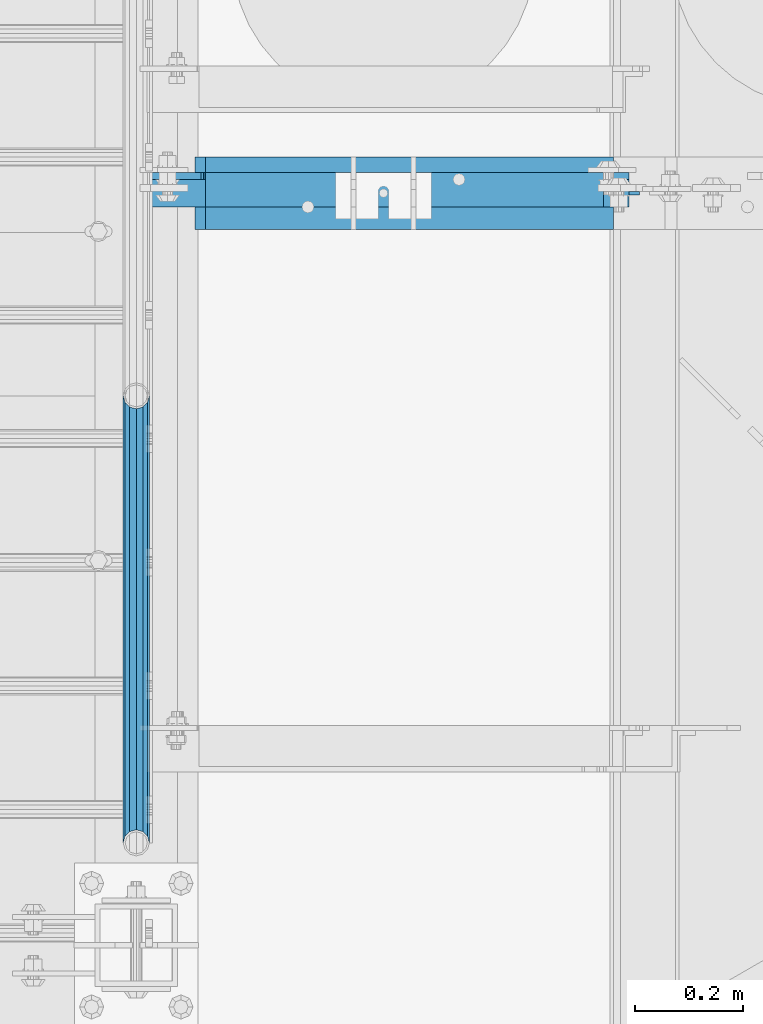
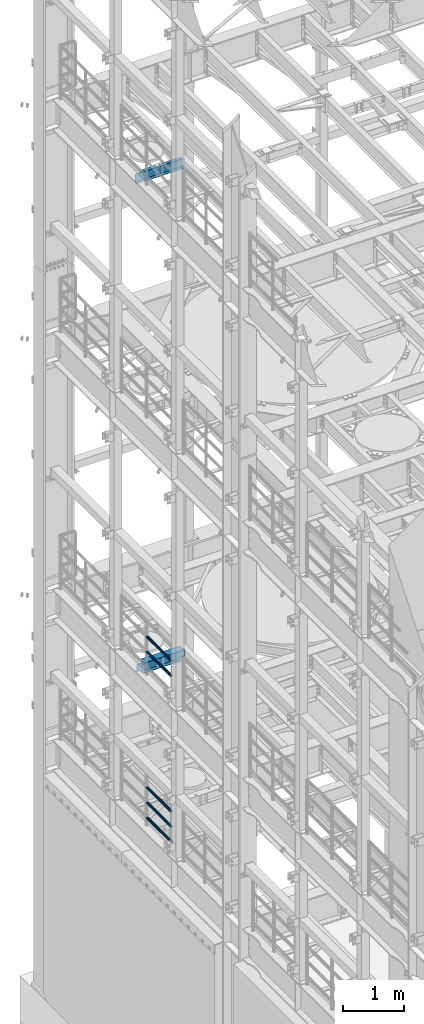
# One storey, part 1304 of 1876: 7 beams, 4 elements without a shape of their own.
"""IFC2X3 building model written with IfcOpenShell, lengths in millimetres."""

from ifc_helpers import new_model, si_unit, frame, origin_with_axes, place, context, subcontext, project, spatial, faceted_brep, material, type_object, element, aggregate, save


model = new_model("IFC2X3")

# Units and contexts
model_context = context("Model", 3, precision=1e-05, world=origin_with_axes())
body_context = subcontext(model_context, "Body", "Model", "MODEL_VIEW")
ifc_project = project(units=[si_unit("LENGTHUNIT", "METRE", prefix="MILLI"), si_unit("AREAUNIT", "SQUARE_METRE"), si_unit("VOLUMEUNIT", "CUBIC_METRE"), si_unit("MASSUNIT", "GRAM", prefix="KILO"), si_unit("TIMEUNIT", "SECOND"), si_unit("PLANEANGLEUNIT", "RADIAN"), si_unit("SOLIDANGLEUNIT", "STERADIAN"), si_unit("THERMODYNAMICTEMPERATUREUNIT", "DEGREE_CELSIUS"), si_unit("LUMINOUSINTENSITYUNIT", "LUMEN")], contexts=[model_context])

# Site, building, storey
site_placement = place(None, origin_with_axes())
site = spatial("IfcSite", under=ifc_project, at=site_placement, CompositionType="ELEMENT")
building_placement = place(site_placement, origin_with_axes())
building = spatial("IfcBuilding", under=site, at=building_placement, Name="Undefined", CompositionType="ELEMENT")
storey_placement = place(building_placement, origin_with_axes())
storey = spatial("IfcBuildingStorey", under=building, at=storey_placement, Name="Undefined", CompositionType="ELEMENT", Elevation=0.0)

# Assembly, beams
assembly_1_placement = place(storey_placement, origin_with_axes())
assembly_1 = element("IfcElementAssembly", 1, at=assembly_1_placement, inside=storey, Name="RAIL", AssemblyPlace="NOTDEFINED", PredefinedType="RIGID_FRAME")
ifc_material_1 = material()
beam_type_1 = type_object("IfcBeamType", Name="PIPE1-1/2SCH40", PredefinedType="NOTDEFINED")
beam_1_placement = place(assembly_1_placement, frame((-1.81898940354586e-12, 9841.23, 8620.125), z_axis=(0.0, 0.0, -1.0), x_axis=(0.0, 1.0, 0.0)))
beam_1 = element("IfcBeam", 2, at=beam_1_placement, type_object=beam_type_1, material=ifc_material_1, Name="RAIL", ObjectType="PIPE1-1/2SCH40", context=body_context, shape_type="Brep", body=[
    faceted_brep([(0.0, 24.1299999999992, 0.0), (12.0650000000064, 20.8971929933177, -12.0649999999987), (12.0650000000064, 20.8971929933177, 12.0649999999987), (12.0650000000064, -20.8971929933177, 12.0649999999987), (12.0650000000064, -20.8971929933177, -12.0649999999987), (0.0, -24.1299999999992, 0.0), (20.8971929933249, -12.0650000000005, 20.8971929933177), (20.8971929933249, -12.0650000000005, 15.8661214311796), (15.2545715621445, -17.7076214311801, 10.2235000000001), (12.5151929933249, -20.4470000000001, 0.0), (15.2545715621445, -17.7076214311801, -10.2235000000001), (20.8971929933249, -12.0650000000005, -15.8661214311796), (20.8971929933249, -12.0650000000005, -20.8971929933177), (24.1300000000063, 0.0, -20.4470000000001), (24.1300000000063, 0.0, -24.130000000001), (21.3906214311868, -10.2235000000001, -17.7076214311819), (21.3906214311868, 10.2235000000001, -17.7076214311819), (20.8971929933249, 12.0650000000005, -15.8661214311796), (20.8971929933249, 12.0650000000005, -20.8971929933177), (15.2545715621445, 17.7076214311801, -10.2235000000001), (12.5151929933249, 20.4470000000001, 0.0), (15.2545715621445, 17.7076214311801, 10.2235000000001), (20.8971929933249, 12.0650000000005, 15.8661214311796), (20.8971929933249, 12.0650000000005, 20.8971929933177), (21.3906214311868, 10.2235000000001, 17.7076214311819), (24.1300000000064, 0.0, 20.4470000000001), (24.1300000000064, 0.0, 24.130000000001), (21.3906214311868, -10.2235000000001, 17.7076214311819), (826.77, 24.1300000000001, 0.0), (814.705, 20.8971929933186, -12.0649999999987), (805.872807006681, 12.0649999999996, -20.8971929933177), (826.77, -24.1300000000001, 0.0), (814.705, -20.8971929933186, -12.0649999999987), (814.705, -20.8971929933186, 12.0649999999987), (805.872807006681, -12.0649999999996, 20.8971929933177), (805.872807006681, -12.0649999999996, -20.8971929933177), (802.640000000001, 0.0, -24.130000000001), (805.379378568819, 10.2235000000001, -17.7076214311819), (802.640000000001, 0.0, -20.4470000000001), (805.872807006683, 12.0649999999996, -15.8661214311796), (805.872807006683, -12.0649999999996, -15.8661214311796), (805.379378568819, -10.2235000000001, -17.7076214311819), (811.515428437862, -17.7076214311801, -10.2235000000001), (814.254807006682, -20.4470000000001, 0.0), (811.515428437862, -17.7076214311801, 10.2235000000001), (805.872807006683, -12.0649999999996, 15.8661214311796), (805.379378568819, -10.2235000000001, 17.7076214311819), (802.640000000001, 0.0, 20.4470000000001), (802.640000000001, 0.0, 24.130000000001), (805.872807006681, 12.0649999999996, 20.8971929933177), (814.705, 20.8971929933186, 12.0649999999987), (805.872807006683, 12.0649999999996, 15.8661214311796), (811.515428437862, 17.7076214311801, 10.2235000000001), (814.254807006682, 20.4470000000001, 0.0), (811.515428437862, 17.7076214311801, -10.2235000000001), (805.379378568819, 10.2235000000001, 17.7076214311819)], [[[0, 1, 2]], [[3, 4, 5]], [[6, 7, 8, 9, 10, 11, 12, 4, 3]], [[13, 14, 12, 11, 15]], [[16, 17, 18, 14, 13]], [[2, 1, 18, 17, 19, 20, 21, 22, 23]], [[23, 22, 24, 25, 26]], [[26, 25, 27, 7, 6]], [[1, 0, 28, 29]], [[18, 1, 29, 30]], [[31, 32, 33]], [[6, 3, 33, 34]], [[3, 5, 31, 33]], [[5, 4, 32, 31]], [[4, 12, 35, 32]], [[12, 14, 36, 35]], [[14, 18, 30, 36]], [[37, 38, 36, 30, 39]], [[40, 35, 36, 38, 41]], [[33, 32, 35, 40, 42, 43, 44, 45, 34]], [[34, 45, 46, 47, 48]], [[26, 6, 34, 48]], [[2, 23, 49, 50]], [[23, 26, 48, 49]], [[0, 2, 50, 28]], [[28, 50, 29]], [[49, 51, 52, 53, 54, 39, 30, 29, 50]], [[48, 47, 55, 51, 49]], [[25, 24, 55, 47]], [[55, 24, 22, 21, 52, 51]], [[21, 20, 53, 52]], [[20, 19, 54, 53]], [[19, 17, 16, 37, 39, 54]], [[16, 13, 38, 37]], [[13, 15, 41, 38]], [[41, 15, 11, 10, 42, 40]], [[10, 9, 43, 42]], [[9, 8, 44, 43]], [[8, 7, 27, 46, 45, 44]], [[27, 25, 47, 46]]]),
])
beam_2_placement = place(assembly_1_placement, frame((-1.81898940354586e-12, 9841.23, 8924.925), z_axis=(0.0, 0.0, -1.0), x_axis=(0.0, 1.0, 0.0)))
beam_2 = element("IfcBeam", 3, at=beam_2_placement, type_object=beam_type_1, material=ifc_material_1, Name="RAIL", ObjectType="PIPE1-1/2SCH40", context=body_context, shape_type="Brep", body=[
    faceted_brep([(0.0, 24.1299999999992, 0.0), (12.0650000000064, 20.8971929933177, -12.0649999999987), (12.0650000000064, 20.8971929933177, 12.0649999999987), (12.0650000000064, -20.8971929933177, 12.0649999999987), (12.0650000000064, -20.8971929933177, -12.0649999999987), (0.0, -24.1299999999992, 0.0), (20.8971929933249, -12.0650000000005, 20.8971929933177), (20.8971929933249, -12.0650000000005, 15.8661214311796), (15.2545715621445, -17.7076214311801, 10.2235000000001), (12.5151929933249, -20.4470000000001, 0.0), (15.2545715621445, -17.7076214311801, -10.2235000000001), (20.8971929933249, -12.0650000000005, -15.8661214311796), (20.8971929933249, -12.0650000000005, -20.8971929933177), (24.1300000000063, 0.0, -20.4470000000001), (24.1300000000063, 0.0, -24.130000000001), (21.3906214311868, -10.2235000000001, -17.7076214311819), (21.3906214311868, 10.2235000000001, -17.7076214311819), (20.8971929933249, 12.0650000000005, -15.8661214311796), (20.8971929933249, 12.0650000000005, -20.8971929933177), (15.2545715621445, 17.7076214311801, -10.2235000000001), (12.5151929933249, 20.4470000000001, 0.0), (15.2545715621445, 17.7076214311801, 10.2235000000001), (20.8971929933249, 12.0650000000005, 15.8661214311796), (20.8971929933249, 12.0650000000005, 20.8971929933177), (21.3906214311868, 10.2235000000001, 17.7076214311819), (24.1300000000064, 0.0, 20.4470000000001), (24.1300000000064, 0.0, 24.130000000001), (21.3906214311868, -10.2235000000001, 17.7076214311819), (826.77, 24.1300000000001, 0.0), (814.705, 20.8971929933186, -12.0649999999987), (805.872807006681, 12.0649999999996, -20.8971929933177), (826.77, -24.1300000000001, 0.0), (814.705, -20.8971929933186, -12.0649999999987), (814.705, -20.8971929933186, 12.0649999999987), (805.872807006681, -12.0649999999996, 20.8971929933177), (805.872807006681, -12.0649999999996, -20.8971929933177), (802.640000000001, 0.0, -24.130000000001), (805.379378568819, 10.2235000000001, -17.7076214311819), (802.640000000001, 0.0, -20.4470000000001), (805.872807006683, 12.0649999999996, -15.8661214311796), (805.872807006683, -12.0649999999996, -15.8661214311796), (805.379378568819, -10.2235000000001, -17.7076214311819), (811.515428437862, -17.7076214311801, -10.2235000000001), (814.254807006682, -20.4470000000001, 0.0), (811.515428437862, -17.7076214311801, 10.2235000000001), (805.872807006683, -12.0649999999996, 15.8661214311796), (805.379378568819, -10.2235000000001, 17.7076214311819), (802.640000000001, 0.0, 20.4470000000001), (802.640000000001, 0.0, 24.130000000001), (805.872807006681, 12.0649999999996, 20.8971929933177), (814.705, 20.8971929933186, 12.0649999999987), (805.872807006683, 12.0649999999996, 15.8661214311796), (811.515428437862, 17.7076214311801, 10.2235000000001), (814.254807006682, 20.4470000000001, 0.0), (811.515428437862, 17.7076214311801, -10.2235000000001), (805.379378568819, 10.2235000000001, 17.7076214311819)], [[[0, 1, 2]], [[3, 4, 5]], [[6, 7, 8, 9, 10, 11, 12, 4, 3]], [[13, 14, 12, 11, 15]], [[16, 17, 18, 14, 13]], [[2, 1, 18, 17, 19, 20, 21, 22, 23]], [[23, 22, 24, 25, 26]], [[26, 25, 27, 7, 6]], [[1, 0, 28, 29]], [[18, 1, 29, 30]], [[31, 32, 33]], [[6, 3, 33, 34]], [[3, 5, 31, 33]], [[5, 4, 32, 31]], [[4, 12, 35, 32]], [[12, 14, 36, 35]], [[14, 18, 30, 36]], [[37, 38, 36, 30, 39]], [[40, 35, 36, 38, 41]], [[33, 32, 35, 40, 42, 43, 44, 45, 34]], [[34, 45, 46, 47, 48]], [[26, 6, 34, 48]], [[2, 23, 49, 50]], [[23, 26, 48, 49]], [[0, 2, 50, 28]], [[28, 50, 29]], [[49, 51, 52, 53, 54, 39, 30, 29, 50]], [[48, 47, 55, 51, 49]], [[25, 24, 55, 47]], [[55, 24, 22, 21, 52, 51]], [[21, 20, 53, 52]], [[20, 19, 54, 53]], [[19, 17, 16, 37, 39, 54]], [[16, 13, 38, 37]], [[13, 15, 41, 38]], [[41, 15, 11, 10, 42, 40]], [[10, 9, 43, 42]], [[9, 8, 44, 43]], [[8, 7, 27, 46, 45, 44]], [[27, 25, 47, 46]]]),
])
aggregate(assembly_1, [beam_1, beam_2])

assembly_2_placement = place(storey_placement, origin_with_axes())
assembly_2 = element("IfcElementAssembly", 4, at=assembly_2_placement, inside=storey, Name="RAIL", AssemblyPlace="NOTDEFINED", PredefinedType="RIGID_FRAME")
beam_3_placement = place(assembly_2_placement, frame((-1.81898940354586e-12, 10668.0, 5292.725), z_axis=(0.0, 0.0, 1.0), x_axis=(0.0, -1.0, 0.0)))
beam_3 = element("IfcBeam", 5, at=beam_3_placement, type_object=beam_type_1, material=ifc_material_1, Name="RAIL", ObjectType="PIPE1-1/2SCH40", context=body_context, shape_type="Brep", body=[
    faceted_brep([(805.872807006681, -12.0649999999996, 20.8971929933177), (805.872807006683, -12.0649999999996, 15.8661214311796), (805.379378568819, -10.2235000000001, 17.7076214311819), (802.640000000001, 0.0, 20.4470000000001), (802.640000000001, 0.0, 24.130000000001), (805.379378568819, 10.2235000000001, 17.7076214311819), (805.872807006683, 12.0649999999996, 15.8661214311796), (805.872807006681, 12.0649999999996, 20.8971929933177), (826.77, 24.1300000000001, 0.0), (814.705, 20.8971929933186, 12.0649999999987), (814.705, 20.8971929933186, -12.0649999999987), (811.515428437862, 17.7076214311801, 10.2235000000001), (814.254807006682, 20.4470000000001, 0.0), (811.515428437862, 17.7076214311801, -10.2235000000001), (805.872807006683, 12.0649999999996, -15.8661214311796), (805.872807006681, 12.0649999999996, -20.8971929933177), (805.379378568819, 10.2235000000001, -17.7076214311819), (802.640000000001, 0.0, -20.4470000000001), (802.640000000001, 0.0, -24.130000000001), (805.872807006683, -12.0649999999996, -15.8661214311796), (805.872807006681, -12.0649999999996, -20.8971929933177), (805.379378568819, -10.2235000000001, -17.7076214311819), (826.77, -24.1300000000001, 0.0), (814.705, -20.8971929933186, -12.0649999999987), (814.705, -20.8971929933186, 12.0649999999987), (811.515428437862, -17.7076214311801, -10.2235000000001), (814.254807006682, -20.4470000000001, 0.0), (811.515428437862, -17.7076214311801, 10.2235000000001), (12.0650000000064, -20.8971929933177, -12.0649999999987), (20.8971929933249, -12.0650000000005, -20.8971929933177), (0.0, 24.1299999999992, 0.0), (12.0650000000064, 20.8971929933177, -12.0649999999987), (12.0650000000064, 20.8971929933177, 12.0649999999987), (20.8971929933249, 12.0650000000005, 20.8971929933177), (24.1300000000064, 0.0, 24.130000000001), (20.8971929933249, 12.0650000000005, -20.8971929933177), (24.1300000000063, 0.0, -24.130000000001), (24.1300000000063, 0.0, -20.4470000000001), (20.8971929933249, -12.0650000000005, -15.8661214311796), (21.3906214311868, -10.2235000000001, -17.7076214311819), (21.3906214311868, 10.2235000000001, -17.7076214311819), (20.8971929933249, 12.0650000000005, -15.8661214311796), (15.2545715621445, 17.7076214311801, -10.2235000000001), (12.5151929933249, 20.4470000000001, 0.0), (15.2545715621445, 17.7076214311801, 10.2235000000001), (20.8971929933249, 12.0650000000005, 15.8661214311796), (21.3906214311868, 10.2235000000001, 17.7076214311819), (24.1300000000064, 0.0, 20.4470000000001), (21.3906214311868, -10.2235000000001, 17.7076214311819), (20.8971929933249, -12.0650000000005, 15.8661214311796), (20.8971929933249, -12.0650000000005, 20.8971929933177), (12.0650000000064, -20.8971929933177, 12.0649999999987), (0.0, -24.1299999999992, 0.0), (15.2545715621445, -17.7076214311801, 10.2235000000001), (12.5151929933249, -20.4470000000001, 0.0), (15.2545715621445, -17.7076214311801, -10.2235000000001)], [[[0, 1, 2, 3, 4]], [[4, 3, 5, 6, 7]], [[8, 9, 10]], [[7, 6, 11, 12, 13, 14, 15, 10, 9]], [[16, 17, 18, 15, 14]], [[19, 20, 18, 17, 21]], [[22, 23, 24]], [[24, 23, 20, 19, 25, 26, 27, 1, 0]], [[28, 29, 20, 23]], [[30, 31, 32]], [[33, 34, 4, 7]], [[32, 33, 7, 9]], [[30, 32, 9, 8]], [[31, 30, 8, 10]], [[35, 31, 10, 15]], [[36, 35, 15, 18]], [[29, 36, 18, 20]], [[37, 36, 29, 38, 39]], [[40, 41, 35, 36, 37]], [[32, 31, 35, 41, 42, 43, 44, 45, 33]], [[33, 45, 46, 47, 34]], [[34, 47, 48, 49, 50]], [[34, 50, 0, 4]], [[50, 51, 24, 0]], [[51, 52, 22, 24]], [[52, 28, 23, 22]], [[51, 28, 52]], [[50, 49, 53, 54, 55, 38, 29, 28, 51]], [[55, 54, 26, 25]], [[21, 39, 38, 55, 25, 19]], [[37, 39, 21, 17]], [[40, 37, 17, 16]], [[42, 41, 40, 16, 14, 13]], [[43, 42, 13, 12]], [[44, 43, 12, 11]], [[5, 46, 45, 44, 11, 6]], [[47, 46, 5, 3]], [[48, 47, 3, 2]], [[53, 49, 48, 2, 1, 27]], [[54, 53, 27, 26]]]),
])
beam_4_placement = place(assembly_2_placement, frame((-1.81898940354586e-12, 9841.23, 5597.525), z_axis=(0.0, 0.0, -1.0), x_axis=(0.0, 1.0, 0.0)))
beam_4 = element("IfcBeam", 6, at=beam_4_placement, type_object=beam_type_1, material=ifc_material_1, Name="RAIL", ObjectType="PIPE1-1/2SCH40", context=body_context, shape_type="Brep", body=[
    faceted_brep([(0.0, 24.1299999999992, 0.0), (12.0650000000064, 20.8971929933177, -12.0649999999987), (12.0650000000064, 20.8971929933177, 12.0649999999987), (12.0650000000064, -20.8971929933177, 12.0649999999987), (12.0650000000064, -20.8971929933177, -12.0649999999987), (0.0, -24.1299999999992, 0.0), (20.8971929933249, -12.0650000000005, 20.8971929933177), (20.8971929933249, -12.0650000000005, 15.8661214311796), (15.2545715621445, -17.7076214311801, 10.2235000000001), (12.5151929933249, -20.4470000000001, 0.0), (15.2545715621445, -17.7076214311801, -10.2235000000001), (20.8971929933249, -12.0650000000005, -15.8661214311796), (20.8971929933249, -12.0650000000005, -20.8971929933177), (24.1300000000063, 0.0, -20.4470000000001), (24.1300000000063, 0.0, -24.130000000001), (21.3906214311868, -10.2235000000001, -17.7076214311819), (21.3906214311868, 10.2235000000001, -17.7076214311819), (20.8971929933249, 12.0650000000005, -15.8661214311796), (20.8971929933249, 12.0650000000005, -20.8971929933177), (15.2545715621445, 17.7076214311801, -10.2235000000001), (12.5151929933249, 20.4470000000001, 0.0), (15.2545715621445, 17.7076214311801, 10.2235000000001), (20.8971929933249, 12.0650000000005, 15.8661214311796), (20.8971929933249, 12.0650000000005, 20.8971929933177), (21.3906214311868, 10.2235000000001, 17.7076214311819), (24.1300000000064, 0.0, 20.4470000000001), (24.1300000000064, 0.0, 24.130000000001), (21.3906214311868, -10.2235000000001, 17.7076214311819), (826.77, 24.1300000000001, 0.0), (814.705, 20.8971929933186, -12.0649999999987), (805.872807006681, 12.0649999999996, -20.8971929933177), (826.77, -24.1300000000001, 0.0), (814.705, -20.8971929933186, -12.0649999999987), (814.705, -20.8971929933186, 12.0649999999987), (805.872807006681, -12.0649999999996, 20.8971929933177), (805.872807006681, -12.0649999999996, -20.8971929933177), (802.640000000001, 0.0, -24.130000000001), (805.379378568819, 10.2235000000001, -17.7076214311819), (802.640000000001, 0.0, -20.4470000000001), (805.872807006683, 12.0649999999996, -15.8661214311796), (805.872807006683, -12.0649999999996, -15.8661214311796), (805.379378568819, -10.2235000000001, -17.7076214311819), (811.515428437862, -17.7076214311801, -10.2235000000001), (814.254807006682, -20.4470000000001, 0.0), (811.515428437862, -17.7076214311801, 10.2235000000001), (805.872807006683, -12.0649999999996, 15.8661214311796), (805.379378568819, -10.2235000000001, 17.7076214311819), (802.640000000001, 0.0, 20.4470000000001), (802.640000000001, 0.0, 24.130000000001), (805.872807006681, 12.0649999999996, 20.8971929933177), (814.705, 20.8971929933186, 12.0649999999987), (805.872807006683, 12.0649999999996, 15.8661214311796), (811.515428437862, 17.7076214311801, 10.2235000000001), (814.254807006682, 20.4470000000001, 0.0), (811.515428437862, 17.7076214311801, -10.2235000000001), (805.379378568819, 10.2235000000001, 17.7076214311819)], [[[0, 1, 2]], [[3, 4, 5]], [[6, 7, 8, 9, 10, 11, 12, 4, 3]], [[13, 14, 12, 11, 15]], [[16, 17, 18, 14, 13]], [[2, 1, 18, 17, 19, 20, 21, 22, 23]], [[23, 22, 24, 25, 26]], [[26, 25, 27, 7, 6]], [[1, 0, 28, 29]], [[18, 1, 29, 30]], [[31, 32, 33]], [[6, 3, 33, 34]], [[3, 5, 31, 33]], [[5, 4, 32, 31]], [[4, 12, 35, 32]], [[12, 14, 36, 35]], [[14, 18, 30, 36]], [[37, 38, 36, 30, 39]], [[40, 35, 36, 38, 41]], [[33, 32, 35, 40, 42, 43, 44, 45, 34]], [[34, 45, 46, 47, 48]], [[26, 6, 34, 48]], [[2, 23, 49, 50]], [[23, 26, 48, 49]], [[0, 2, 50, 28]], [[28, 50, 29]], [[49, 51, 52, 53, 54, 39, 30, 29, 50]], [[48, 47, 55, 51, 49]], [[25, 24, 55, 47]], [[55, 24, 22, 21, 52, 51]], [[21, 20, 53, 52]], [[20, 19, 54, 53]], [[19, 17, 16, 37, 39, 54]], [[16, 13, 38, 37]], [[13, 15, 41, 38]], [[41, 15, 11, 10, 42, 40]], [[10, 9, 43, 42]], [[9, 8, 44, 43]], [[8, 7, 27, 46, 45, 44]], [[27, 25, 47, 46]]]),
])
beam_5_placement = place(assembly_2_placement, frame((-1.81898940354586e-12, 9841.23, 5902.325), z_axis=(0.0, 0.0, -1.0), x_axis=(0.0, 1.0, 0.0)))
beam_5 = element("IfcBeam", 7, at=beam_5_placement, type_object=beam_type_1, material=ifc_material_1, Name="RAIL", ObjectType="PIPE1-1/2SCH40", context=body_context, shape_type="Brep", body=[
    faceted_brep([(0.0, 24.1299999999992, 0.0), (12.0650000000064, 20.8971929933177, -12.0649999999987), (12.0650000000064, 20.8971929933177, 12.0649999999987), (12.0650000000064, -20.8971929933177, 12.0649999999987), (12.0650000000064, -20.8971929933177, -12.0649999999987), (0.0, -24.1299999999992, 0.0), (20.8971929933249, -12.0650000000005, 20.8971929933177), (20.8971929933249, -12.0650000000005, 15.8661214311796), (15.2545715621445, -17.7076214311801, 10.2235000000001), (12.5151929933249, -20.4470000000001, 0.0), (15.2545715621445, -17.7076214311801, -10.2235000000001), (20.8971929933249, -12.0650000000005, -15.8661214311796), (20.8971929933249, -12.0650000000005, -20.8971929933177), (24.1300000000063, 0.0, -20.4470000000001), (24.1300000000063, 0.0, -24.130000000001), (21.3906214311868, -10.2235000000001, -17.7076214311819), (21.3906214311868, 10.2235000000001, -17.7076214311819), (20.8971929933249, 12.0650000000005, -15.8661214311796), (20.8971929933249, 12.0650000000005, -20.8971929933177), (15.2545715621445, 17.7076214311801, -10.2235000000001), (12.5151929933249, 20.4470000000001, 0.0), (15.2545715621445, 17.7076214311801, 10.2235000000001), (20.8971929933249, 12.0650000000005, 15.8661214311796), (20.8971929933249, 12.0650000000005, 20.8971929933177), (21.3906214311868, 10.2235000000001, 17.7076214311819), (24.1300000000064, 0.0, 20.4470000000001), (24.1300000000064, 0.0, 24.130000000001), (21.3906214311868, -10.2235000000001, 17.7076214311819), (826.77, 24.1300000000001, 0.0), (814.705, 20.8971929933186, -12.0649999999987), (805.872807006681, 12.0649999999996, -20.8971929933177), (826.77, -24.1300000000001, 0.0), (814.705, -20.8971929933186, -12.0649999999987), (814.705, -20.8971929933186, 12.0649999999987), (805.872807006681, -12.0649999999996, 20.8971929933177), (805.872807006681, -12.0649999999996, -20.8971929933177), (802.640000000001, 0.0, -24.130000000001), (805.379378568819, 10.2235000000001, -17.7076214311819), (802.640000000001, 0.0, -20.4470000000001), (805.872807006683, 12.0649999999996, -15.8661214311796), (805.872807006683, -12.0649999999996, -15.8661214311796), (805.379378568819, -10.2235000000001, -17.7076214311819), (811.515428437862, -17.7076214311801, -10.2235000000001), (814.254807006682, -20.4470000000001, 0.0), (811.515428437862, -17.7076214311801, 10.2235000000001), (805.872807006683, -12.0649999999996, 15.8661214311796), (805.379378568819, -10.2235000000001, 17.7076214311819), (802.640000000001, 0.0, 20.4470000000001), (802.640000000001, 0.0, 24.130000000001), (805.872807006681, 12.0649999999996, 20.8971929933177), (814.705, 20.8971929933186, 12.0649999999987), (805.872807006683, 12.0649999999996, 15.8661214311796), (811.515428437862, 17.7076214311801, 10.2235000000001), (814.254807006682, 20.4470000000001, 0.0), (811.515428437862, 17.7076214311801, -10.2235000000001), (805.379378568819, 10.2235000000001, 17.7076214311819)], [[[0, 1, 2]], [[3, 4, 5]], [[6, 7, 8, 9, 10, 11, 12, 4, 3]], [[13, 14, 12, 11, 15]], [[16, 17, 18, 14, 13]], [[2, 1, 18, 17, 19, 20, 21, 22, 23]], [[23, 22, 24, 25, 26]], [[26, 25, 27, 7, 6]], [[1, 0, 28, 29]], [[18, 1, 29, 30]], [[31, 32, 33]], [[6, 3, 33, 34]], [[3, 5, 31, 33]], [[5, 4, 32, 31]], [[4, 12, 35, 32]], [[12, 14, 36, 35]], [[14, 18, 30, 36]], [[37, 38, 36, 30, 39]], [[40, 35, 36, 38, 41]], [[33, 32, 35, 40, 42, 43, 44, 45, 34]], [[34, 45, 46, 47, 48]], [[26, 6, 34, 48]], [[2, 23, 49, 50]], [[23, 26, 48, 49]], [[0, 2, 50, 28]], [[28, 50, 29]], [[49, 51, 52, 53, 54, 39, 30, 29, 50]], [[48, 47, 55, 51, 49]], [[25, 24, 55, 47]], [[55, 24, 22, 21, 52, 51]], [[21, 20, 53, 52]], [[20, 19, 54, 53]], [[19, 17, 16, 37, 39, 54]], [[16, 13, 38, 37]], [[13, 15, 41, 38]], [[41, 15, 11, 10, 42, 40]], [[10, 9, 43, 42]], [[9, 8, 44, 43]], [[8, 7, 27, 46, 45, 44]], [[27, 25, 47, 46]]]),
])
aggregate(assembly_2, [beam_3, beam_4, beam_5])

# Assembly, beam
assembly_3_placement = place(storey_placement, origin_with_axes())
assembly_3 = element("IfcElementAssembly", 8, at=assembly_3_placement, inside=storey, Name="BEAM", AssemblyPlace="NOTDEFINED", PredefinedType="RIGID_FRAME")
ifc_material_2 = material(Name="STEEL/A992")
beam_type_2 = type_object("IfcBeamType", Name="W8X18", PredefinedType="NOTDEFINED")
beam_6_placement = place(assembly_3_placement, frame((0.0, 11042.65, 8050.2125), z_axis=(0.0, 0.0, 1.0), x_axis=(1.0, 0.0, 0.0)))
beam_6 = element("IfcBeam", 9, at=beam_6_placement, type_object=beam_type_2, material=ifc_material_2, Name="BEAM", ObjectType="W8X18", context=body_context, shape_type="Brep", body=[
    faceted_brep([(19.8437500000002, -3.17500000000018, -77.7874999999985), (19.8437500000002, 3.17500000000018, -77.7874999999985), (96.043750190735, 3.17499999999927, -77.7875000000004), (96.043750190735, -3.17499999999927, -77.7875000000004), (100.903829708781, 3.17499999999927, -78.7542299225879), (100.903829708781, -3.17499999999927, -78.7542299225879), (105.024006176934, 3.17499999999927, -81.5072438230654), (105.024006176934, -3.17499999999927, -81.5072438230654), (107.777020077412, 3.17499999999927, -85.6274202912191), (107.777020077412, -3.17499999999927, -85.6274202912191), (108.74375, -3.17499999999927, -90.4874998092655), (108.74375, 3.17499999999927, -90.4874998092655), (108.74375, 3.17499999999927, -95.25), (108.74375, 66.6749999999993, -95.25), (108.74375, 66.6750000000002, -103.1875), (108.74375, -66.6750000000002, -103.1875), (108.74375, -66.6749999999993, -95.25), (108.74375, -3.17499999999927, -95.25), (127.79375, 66.6749999999993, 103.1875), (127.79375, -66.6749999999993, 103.1875), (882.649999999999, -66.6749999999993, 103.1875), (882.649999999999, 66.6749999999993, 103.1875), (127.79375, -66.6749999999993, 95.25), (882.965773345275, -66.6749999999993, 95.25), (882.649999999999, -66.6749999999993, 96.837499809264), (882.649999999999, 66.6749999999993, 96.837499809264), (127.79375, 66.6749999999993, 95.25), (882.965773345275, 66.6749999999993, 95.25), (127.79375, 3.17499999999927, 95.25), (882.965773345275, 3.17499999999927, 95.25), (115.093750190735, -3.17499999999927, 71.4375), (115.093750190735, 3.17499999999927, 71.4375), (19.8437499999999, 3.17499999999927, 71.4375), (19.8437499999999, -3.17499999999927, 71.4375), (119.953829708781, -3.17499999999927, 72.4042299225875), (119.953829708781, 3.17499999999927, 72.4042299225875), (124.074006176934, -3.17499999999927, 75.1572438230651), (124.074006176934, 3.17499999999927, 75.1572438230651), (126.827020077412, -3.17499999999927, 79.2774202912187), (126.827020077412, 3.17499999999927, 79.2774202912187), (127.79375, -3.17499999999927, 84.1374998092651), (127.79375, 3.17499999999927, 84.1374998092651), (127.79375, -3.17499999999927, 95.25), (882.965773345275, -3.17499999999927, 95.25), (883.616729922587, -3.17499999999927, 91.9774202912186), (883.616729922587, 3.17499999999927, 91.9774202912186), (886.369743823065, -3.17499999999927, 87.8572438230649), (886.369743823065, 3.17499999999927, 87.8572438230649), (890.489920291219, -3.17499999999927, 85.1042299225865), (890.489920291219, 3.17499999999927, 85.1042299225865), (895.349999809265, -3.17499999999927, 84.1374999999989), (895.349999809265, 3.17499999999927, 84.1374999999989), (930.275, -3.17499999999927, 84.1374999999989), (930.275, 3.17499999999927, 84.1374999999989), (930.275, -3.17499999999927, -77.7875000000013), (930.275, 3.17499999999927, -77.7875000000013), (854.074999809265, -3.17499999999927, -77.7875000000013), (854.074999809265, 3.17499999999927, -77.7875000000013), (849.214920291219, -3.17499999999927, -78.7542299225888), (849.214920291219, 3.17499999999927, -78.7542299225888), (845.094743823065, -3.17499999999927, -81.5072438230673), (845.094743823065, 3.17499999999927, -81.5072438230673), (842.341729922587, -3.17499999999927, -85.6274202912209), (842.341729922587, 3.17499999999927, -85.6274202912209), (841.374999999999, -3.17499999999927, -90.4874998092664), (841.374999999999, 3.17499999999927, -90.4874998092664), (841.374999999999, -3.17499999999927, -95.25), (841.374999999999, -66.6749999999993, -95.25), (841.374999999999, -66.6749999999993, -103.1875), (841.374999999999, 66.6749999999993, -103.1875), (841.374999999999, 66.6749999999993, -95.25), (841.374999999999, 3.17499999999927, -95.25)], [[[0, 1, 2, 3]], [[3, 2, 4, 5]], [[5, 4, 6, 7]], [[7, 6, 8, 9]], [[10, 11, 12, 13, 14, 15, 16, 17]], [[9, 8, 11, 10]], [[18, 19, 20, 21]], [[20, 19, 22, 23, 24]], [[20, 24, 25, 21]], [[26, 18, 21, 25, 27]], [[28, 26, 27, 29]], [[30, 31, 32, 33]], [[34, 35, 31, 30]], [[36, 37, 35, 34]], [[38, 39, 37, 36]], [[40, 41, 39, 38]], [[19, 18, 26, 28, 41, 40, 42, 22]], [[22, 42, 43, 23]], [[44, 45, 29, 27, 25, 24, 23, 43]], [[46, 47, 45, 44]], [[48, 49, 47, 46]], [[50, 51, 49, 48]], [[52, 53, 51, 50]], [[53, 52, 54, 55]], [[54, 56, 57, 55]], [[58, 59, 57, 56]], [[60, 61, 59, 58]], [[62, 63, 61, 60]], [[64, 65, 63, 62]], [[66, 67, 68, 69, 70, 71, 65, 64]], [[67, 66, 17, 16]], [[68, 67, 16, 15]], [[69, 68, 15, 14]], [[70, 69, 14, 13]], [[71, 70, 13, 12]], [[6, 4, 2, 1, 32, 31, 35, 37, 39, 41, 28, 29, 45, 47, 49, 51, 53, 55, 57, 59, 61, 63, 65, 71, 12, 11, 8]], [[33, 32, 1, 0]], [[66, 64, 62, 60, 58, 56, 54, 52, 50, 48, 46, 44, 43, 42, 40, 38, 36, 34, 30, 33, 0, 3, 5, 7, 9, 10, 17]]]),
])
aggregate(assembly_3, [beam_6])

assembly_4_placement = place(storey_placement, origin_with_axes())
assembly_4 = element("IfcElementAssembly", 10, at=assembly_4_placement, inside=storey, Name="BEAM", AssemblyPlace="NOTDEFINED", PredefinedType="RIGID_FRAME")
ifc_material_3 = material(Name="STEEL/A36")
beam_type_3 = type_object("IfcBeamType", Name="C8X18.75", PredefinedType="NOTDEFINED")
beam_7_placement = place(assembly_4_placement, frame((-1.70530256582424e-13, 11049.0, 17881.6), z_axis=(0.0, 0.0, 1.0), x_axis=(1.0, 0.0, 0.0)))
beam_7 = element("IfcBeam", 11, at=beam_7_placement, type_object=beam_type_3, material=ifc_material_3, Name="BEAM", ObjectType="C8X18.75", context=body_context, shape_type="Brep", body=[
    faceted_brep([(115.093750190735, 19.0499999999993, 63.5000000000036), (115.093750190735, 31.75, 63.5000000000036), (19.8437500000002, 31.75, 63.4999999999891), (19.8437500000002, 19.05, 63.4999999999891), (119.953829708781, 19.0499999999993, 64.4667299225912), (119.953829708781, 31.75, 64.4667299225912), (124.074006176934, 19.0499999999993, 67.2197438230687), (124.074006176934, 31.75, 67.2197438230687), (126.827020077412, 19.0499999999993, 71.3399202912224), (126.827020077412, 31.75, 71.3399202912224), (127.79375, 19.0499999999993, 76.1999998092688), (127.79375, 31.75, 76.1999998092688), (127.79375, -31.75, 101.599999999999), (127.79375, 31.75, 101.599999999999), (127.79375, 19.0499999999993, 88.9012699999985), (127.79375, -31.75, 97.3645499999984), (19.8437500000002, 19.05, -88.9012699999985), (19.8437500000002, -31.75, -97.3645499999984), (911.225, -31.75, -97.3645499999984), (911.225, 19.0499999999993, -88.9012699999985), (19.8437500000002, -31.75, -101.599999999999), (911.225, -31.75, -101.599999999999), (19.8437500000002, 31.75, -101.599999999999), (911.225, 31.75, -101.599999999999), (911.225, 31.75, 82.5499999999993), (911.225, 19.0499999999993, 82.5499999999993), (876.299999809266, 31.75, 82.5499999999993), (876.299999809266, 19.0499999999993, 82.5499999999993), (871.439920291221, 31.75, 83.5167299225868), (871.439920291221, 19.0499999999993, 83.5167299225868), (867.319743823067, 31.75, 86.2697438230643), (867.319743823067, 19.0499999999993, 86.2697438230643), (864.566729922589, 31.75, 90.389920291218), (864.566729922589, 10.1145240623118, 90.389920291218), (865.561414246514, 19.0499999999993, 88.9012699999985), (863.600000000001, 31.75, 95.2499998092644), (863.600000000001, -19.0576219043487, 95.2499998092644), (863.600000000001, -31.75, 101.599999999999), (863.600000000001, -31.75, 97.3645499999984), (863.600000000001, 31.75, 101.599999999999)], [[[0, 1, 2, 3]], [[4, 5, 1, 0]], [[6, 7, 5, 4]], [[8, 9, 7, 6]], [[10, 11, 9, 8]], [[12, 13, 11, 10, 14, 15]], [[16, 17, 18, 19]], [[17, 20, 21, 18]], [[20, 22, 23, 21]], [[19, 18, 21, 23, 24, 25]], [[25, 24, 26, 27]], [[27, 26, 28, 29]], [[29, 28, 30, 31]], [[31, 30, 32, 33, 34]], [[33, 32, 35, 36]], [[37, 38, 36, 35, 39]], [[38, 37, 12, 15]], [[34, 33, 36, 38, 15, 14]], [[8, 6, 4, 0, 3, 16, 19, 25, 27, 29, 31, 34, 14, 10]], [[22, 20, 17, 16, 3, 2]], [[39, 35, 32, 30, 28, 26, 24, 23, 22, 2, 1, 5, 7, 9, 11, 13]], [[37, 39, 13, 12]]]),
])
aggregate(assembly_4, [beam_7])

save(model, "model.ifc")
